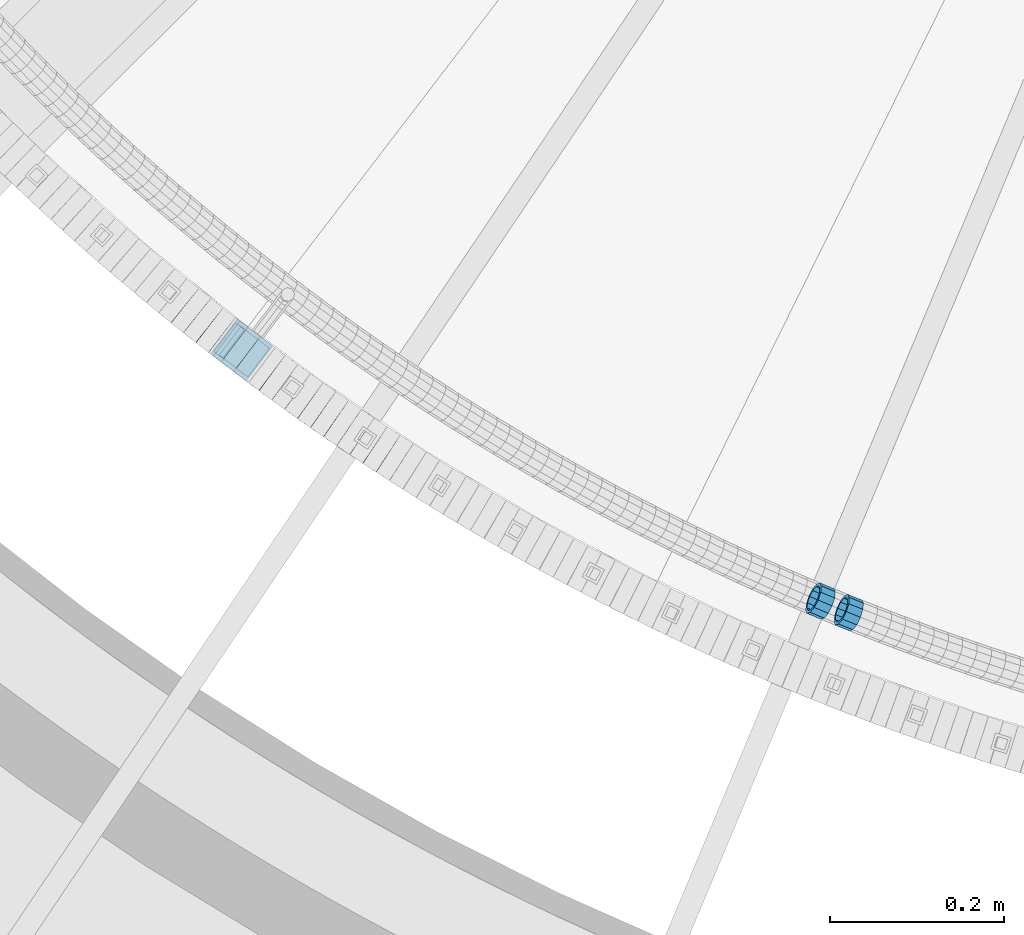
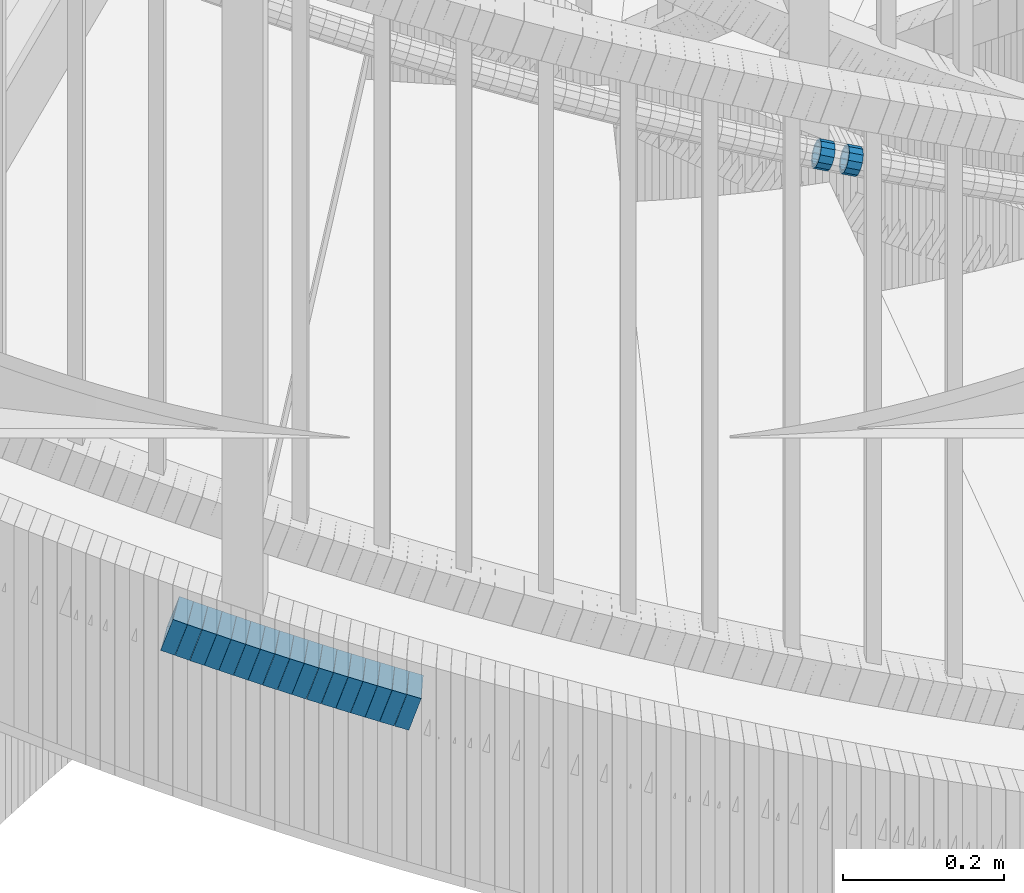
# One storey, part 649 of 975: 19 beams.
"""IFC2X3 building model written with IfcOpenShell, lengths in millimetres."""

from ifc_helpers import new_model, si_unit, frame, origin_with_axes, place, context, subcontext, project, spatial, faceted_brep, material, type_object, element, save


model = new_model("IFC2X3")

# Units and contexts
model_context = context("Model", 3, precision=1e-05, world=origin_with_axes())
body_context = subcontext(model_context, "Body", "Model", "MODEL_VIEW")
ifc_project = project(units=[si_unit("LENGTHUNIT", "METRE", prefix="MILLI"), si_unit("AREAUNIT", "SQUARE_METRE"), si_unit("VOLUMEUNIT", "CUBIC_METRE"), si_unit("MASSUNIT", "GRAM", prefix="KILO"), si_unit("TIMEUNIT", "SECOND"), si_unit("PLANEANGLEUNIT", "RADIAN"), si_unit("SOLIDANGLEUNIT", "STERADIAN"), si_unit("THERMODYNAMICTEMPERATUREUNIT", "DEGREE_CELSIUS"), si_unit("LUMINOUSINTENSITYUNIT", "LUMEN")], contexts=[model_context])

# Site, building, storey
site_placement = place(None, origin_with_axes())
site = spatial("IfcSite", under=ifc_project, at=site_placement, CompositionType="ELEMENT")
building_placement = place(site_placement, origin_with_axes())
building = spatial("IfcBuilding", under=site, at=building_placement, Name="Undefined", CompositionType="ELEMENT")
storey_placement = place(building_placement, origin_with_axes())
storey = spatial("IfcBuildingStorey", under=building, at=storey_placement, Name="Undefined", CompositionType="ELEMENT", Elevation=0.0)

# Beams
ifc_material = material()
beam_type_1 = type_object("IfcBeamType", PredefinedType="NOTDEFINED")
beam_1_placement = place(storey_placement, frame((33653.4322841467, 833.881367147236, 4572.69274639773), z_axis=(0.384208167513556, 0.92324649147228, -2.21253685595002e-10), x_axis=(0.877556871901427, -0.365194474958958, -0.31068783696507)))
element("IfcBeam", 1, at=beam_1_placement, inside=storey, type_object=beam_type_1, material=ifc_material, Name="WALL", context=body_context, shape_type="Brep", body=[
    faceted_brep([(-2.1246523829177e-07, -15.367000000002, 0.0), (-1.83998054126278e-07, -13.3082123799541, 7.68350000000009), (18.3491144200598, -13.3082123799504, 7.68349999999373), (18.3491144200925, -15.3670000000038, 7.27595761418343e-12), (-1.06232619145885e-07, -7.68349999999919, 13.3082123799559), (18.3491144200307, -7.68349999998463, 13.3082123799359), (-3.63797880709171e-12, 3.63797880709171e-12, 15.3670000000002), (18.3491144200016, 2.5465851649642e-11, 15.3669999999674), (1.06225343188271e-07, 7.68350000000646, 13.3082123799559), (18.3491144199943, 7.68350000003193, 13.3082123799177), (1.8399441614747e-07, 13.308212379965, 7.68350000000009), (18.3491144199907, 13.3082123799941, 7.68349999996281), (2.12461600312963e-07, 15.3670000000093, 0.0), (18.3491144200052, 15.3670000000347, -3.09228198602796e-11), (1.8399441614747e-07, 13.308212379965, -7.68350000000009), (18.3491144200379, 13.3082123799832, -7.68350000001556), (1.06225343188271e-07, 7.68350000000646, -13.3082123799559), (18.3491144200707, 7.68350000001374, -13.3082123799577), (-3.63797880709171e-12, 3.63797880709171e-12, -15.3670000000002), (18.3491144200962, 3.63797880709171e-12, -15.3669999999911), (-1.06232619145885e-07, -7.68349999999919, -13.3082123799559), (18.3491144201143, -7.68350000000464, -13.3082123799377), (-1.83998054126278e-07, -13.3082123799541, -7.68350000000009), (18.3491144201107, -13.3082123799632, -7.68349999998645), (-2.63386027654633e-07, -19.0500000000029, 0.0), (-2.28097633225843e-07, -16.4977839420972, -9.52499999999964), (18.349114420118, -16.4977839421044, -9.52499999997963), (18.3491144201034, -19.0500000000102, 1.09139364212751e-11), (-1.31691194837913e-07, -9.52500000000146, -16.4977839420935), (18.3491144201253, -9.52500000000873, -16.4977839420717), (-3.63797880709171e-12, 3.63797880709171e-12, -19.0500000000002), (18.3491144201071, 3.63797880709171e-12, -19.0499999999865), (1.31687556859106e-07, 9.52500000000509, -16.4977839420935), (18.3491144200743, 9.52500000001601, -16.4977839420953), (2.28097633225843e-07, 16.4977839421044, -9.52499999999964), (18.3491144200416, 16.4977839421226, -9.52500000001965), (2.63382389675826e-07, 19.0500000000138, 0.0), (18.3491144199979, 19.0500000000393, -3.63797880709171e-11), (2.28097633225843e-07, 16.4977839421044, 9.52499999999964), (18.3491144199797, 16.4977839421372, 9.52499999995598), (1.31687556859106e-07, 9.52500000000509, 16.4977839420935), (18.3491144199761, 9.52500000003783, 16.497783942048), (-3.63797880709171e-12, 3.63797880709171e-12, 19.0500000000002), (18.3491144199979, 2.72848410531878e-11, 19.0499999999647), (-1.31691194837913e-07, -9.52500000000146, 16.4977839420935), (18.349114420027, -9.52499999998327, 16.4977839420735), (-2.28097633225843e-07, -16.4977839420972, 9.52499999999964), (18.3491144200671, -16.4977839420935, 9.524999999996)], [[[0, 1, 2, 3]], [[1, 4, 5, 2]], [[4, 6, 7, 5]], [[6, 8, 9, 7]], [[8, 10, 11, 9]], [[10, 12, 13, 11]], [[12, 14, 15, 13]], [[14, 16, 17, 15]], [[16, 18, 19, 17]], [[18, 20, 21, 19]], [[20, 22, 23, 21]], [[22, 0, 3, 23]], [[24, 25, 26, 27]], [[25, 28, 29, 26]], [[28, 30, 31, 29]], [[30, 32, 33, 31]], [[32, 34, 35, 33]], [[34, 36, 37, 35]], [[36, 38, 39, 37]], [[38, 40, 41, 39]], [[40, 42, 43, 41]], [[42, 44, 45, 43]], [[44, 46, 47, 45]], [[46, 24, 27, 47]], [[29, 31, 33, 35, 37, 39, 41, 43, 45, 47, 27, 26], [5, 7, 9, 11, 13, 15, 17, 19, 21, 23, 3, 2]], [[46, 44, 42, 40, 38, 36, 34, 32, 30, 28, 25, 24], [22, 20, 18, 16, 14, 12, 10, 8, 6, 4, 1, 0]]]),
])
beam_2_placement = place(storey_placement, frame((33685.730099739, 820.487289697012, 4561.18183881547), z_axis=(0.370407953664464, 0.928869176936184, 9.3559719971381e-11), x_axis=(0.883433150707989, -0.352289292883568, -0.308930610897902)))
element("IfcBeam", 2, at=beam_2_placement, inside=storey, type_object=beam_type_1, material=ifc_material, Name="WALL", context=body_context, shape_type="Brep", body=[
    faceted_brep([(-2.1246523829177e-07, -15.367000000002, 0.0), (-1.83998054126278e-07, -13.3082123799541, 7.68350000000009), (18.4537259110693, -13.3082123799595, 7.68349999998827), (18.453725911073, -15.3670000000038, 0.0), (-1.06232619145885e-07, -7.68349999999919, 13.3082123799559), (18.4537259110621, -7.683500000001, 13.3082123799431), (-3.63797880709171e-12, 3.63797880709171e-12, 15.3670000000002), (18.453725911073, -1.81898940354586e-12, 15.3669999999911), (1.06225343188271e-07, 7.68350000000646, 13.3082123799559), (18.4537259110839, 7.68349999999737, 13.3082123799504), (1.8399441614747e-07, 13.308212379965, 7.68350000000009), (18.4537259110948, 13.3082123799522, 7.68350000000646), (2.12461600312963e-07, 15.3670000000093, 0.0), (18.4537259111057, 15.3669999999947, 1.09139364212751e-11), (1.8399441614747e-07, 13.308212379965, -7.68350000000009), (18.4537259111203, 13.3082123799486, -7.68349999997372), (1.06225343188271e-07, 7.68350000000646, -13.3082123799559), (18.4537259111166, 7.68349999999373, -13.3082123799322), (-3.63797880709171e-12, 3.63797880709171e-12, -15.3670000000002), (18.4537259111094, -5.45696821063757e-12, -15.3669999999765), (-1.06232619145885e-07, -7.68349999999919, -13.3082123799559), (18.4537259111057, -7.68350000000646, -13.3082123799395), (-1.83998054126278e-07, -13.3082123799541, -7.68350000000009), (18.4537259110912, -13.3082123799595, -7.68349999999555), (-2.63386027654633e-07, -19.0500000000029, 0.0), (-2.28097633225843e-07, -16.4977839420972, -9.52499999999964), (18.4537259110839, -16.497783942099, -9.52499999999418), (18.453725911073, -19.0500000000029, -7.27595761418343e-12), (-1.31691194837913e-07, -9.52500000000146, -16.4977839420935), (18.4537259111057, -9.52500000000509, -16.497783942079), (-3.63797880709171e-12, 3.63797880709171e-12, -19.0500000000002), (18.4537259111166, -7.27595761418343e-12, -19.0499999999702), (1.31687556859106e-07, 9.52500000000509, -16.4977839420935), (18.4537259111275, 9.52499999999236, -16.4977839420608), (2.28097633225843e-07, 16.4977839421044, -9.52499999999964), (18.4537259111239, 16.4977839420881, -9.52499999997235), (2.63382389675826e-07, 19.0500000000138, 0.0), (18.4537259111057, 19.0499999999938, 1.81898940354586e-11), (2.28097633225843e-07, 16.4977839421044, 9.52499999999964), (18.4537259110948, 16.4977839420917, 9.52500000000509), (1.31687556859106e-07, 9.52500000000509, 16.4977839420935), (18.4537259110803, 9.52499999999782, 16.4977839420862), (-3.63797880709171e-12, 3.63797880709171e-12, 19.0500000000002), (18.4537259110621, -1.81898940354586e-12, 19.0499999999811), (-1.31691194837913e-07, -9.52500000000146, 16.4977839420935), (18.4537259110584, -9.52500000000146, 16.4977839420753), (-2.28097633225843e-07, -16.4977839420972, 9.52499999999964), (18.4537259110621, -16.4977839420953, 9.52499999998327)], [[[0, 1, 2, 3]], [[1, 4, 5, 2]], [[4, 6, 7, 5]], [[6, 8, 9, 7]], [[8, 10, 11, 9]], [[10, 12, 13, 11]], [[12, 14, 15, 13]], [[14, 16, 17, 15]], [[16, 18, 19, 17]], [[18, 20, 21, 19]], [[20, 22, 23, 21]], [[22, 0, 3, 23]], [[24, 25, 26, 27]], [[25, 28, 29, 26]], [[28, 30, 31, 29]], [[30, 32, 33, 31]], [[32, 34, 35, 33]], [[34, 36, 37, 35]], [[36, 38, 39, 37]], [[38, 40, 41, 39]], [[40, 42, 43, 41]], [[42, 44, 45, 43]], [[44, 46, 47, 45]], [[46, 24, 27, 47]], [[29, 31, 33, 35, 37, 39, 41, 43, 45, 47, 27, 26], [5, 7, 9, 11, 13, 15, 17, 19, 21, 23, 3, 2]], [[46, 44, 42, 40, 38, 36, 34, 32, 30, 28, 25, 24], [22, 20, 18, 16, 14, 12, 10, 8, 6, 4, 1, 0]]]),
])
beam_type_2 = type_object("IfcBeamType", Name="HSS2X2X.188_TUBES", PredefinedType="NOTDEFINED")
beam_3_placement = place(storey_placement, frame((32925.6931023525, 1174.52376086977, 3910.43312083573), z_axis=(0.624695047600639, 0.780868809406059, 1.82944404514274e-10), x_axis=(0.742959140417753, -0.594367312334205, -0.307797358173079)))
element("IfcBeam", 3, at=beam_3_placement, inside=storey, type_object=beam_type_2, material=ifc_material, Name="WALL", ObjectType="HSS2X2X.188_TUBES", context=body_context, shape_type="Brep", body=[
    faceted_brep([(0.0, 20.6374999999753, -20.6375000000298), (0.0, -20.6375000000153, -20.6375000000153), (18.8433011969464, -20.6374999999898, -20.6375000000226), (18.8433011969719, 20.6375000000007, -20.6374999999862), (0.0, -20.6374999999825, 20.6375000000335), (18.8433011969828, -20.6375000000044, 20.6375000000189), (0.0, 20.6375000000116, 20.6375000000189), (18.8433011970155, 20.6374999999862, 20.6375000000517), (0.0, 25.3999999999724, -25.4000000000342), (0.0, 25.400000000016, 25.4000000000196), (18.8433011970228, 25.3999999999833, 25.4000000000597), (18.8433011969719, 25.4000000000015, -25.3999999999869), (0.0, -25.399999999976, 25.4000000000378), (18.8433011969864, -25.4000000000051, 25.4000000000196), (0.0, -25.400000000016, -25.4000000000196), (18.8433011969391, -25.3999999999869, -25.4000000000269)], [[[0, 1, 2, 3]], [[1, 4, 5, 2]], [[4, 6, 7, 5]], [[6, 0, 3, 7]], [[8, 9, 10, 11]], [[9, 12, 13, 10]], [[12, 14, 15, 13]], [[14, 8, 11, 15]], [[13, 15, 11, 10], [5, 7, 3, 2]], [[14, 12, 9, 8], [6, 4, 1, 0]]]),
])
beam_4_placement = place(storey_placement, frame((32939.8354157942, 1163.16701080434, 3904.60164874972), z_axis=(0.621276225268862, 0.78359163594035, -7.90359990787692e-11), x_axis=(0.746520694737996, -0.591884264792277, -0.303940568893337)))
element("IfcBeam", 4, at=beam_4_placement, inside=storey, type_object=beam_type_2, material=ifc_material, Name="WALL", ObjectType="HSS2X2X.188_TUBES", context=body_context, shape_type="Brep", body=[
    faceted_brep([(0.0, 20.6374999999753, -20.6375000000298), (0.0, -20.6375000000153, -20.6375000000153), (18.7547327359644, -20.6374999999844, -20.6375000000553), (18.7547327359898, 20.6375000000171, -20.6375000000335), (0.0, -20.6374999999825, 20.6375000000335), (18.7547327360044, -20.6374999999953, 20.6374999999898), (0.0, 20.6375000000116, 20.6375000000189), (18.7547327360262, 20.6375000000062, 20.6375000000116), (0.0, 25.3999999999724, -25.4000000000342), (0.0, 25.400000000016, 25.4000000000196), (18.7547327360371, 25.4000000000033, 25.4000000000124), (18.7547327359898, 25.4000000000178, -25.4000000000342), (0.0, -25.399999999976, 25.4000000000378), (18.7547327360044, -25.399999999996, 25.3999999999869), (0.0, -25.400000000016, -25.4000000000196), (18.7547327359498, -25.3999999999814, -25.4000000000597)], [[[0, 1, 2, 3]], [[1, 4, 5, 2]], [[4, 6, 7, 5]], [[6, 0, 3, 7]], [[8, 9, 10, 11]], [[9, 12, 13, 10]], [[12, 14, 15, 13]], [[14, 8, 11, 15]], [[13, 15, 11, 10], [5, 7, 3, 2]], [[14, 12, 9, 8], [6, 4, 1, 0]]]),
])
beam_5_placement = place(storey_placement, frame((32954.0367563121, 1151.79884361767, 3898.88975745706), z_axis=(0.612397742431603, 0.790549811880742, -1.31450178741943e-10), x_axis=(0.75351979107376, -0.583712515057146, -0.302469212029619)))
element("IfcBeam", 5, at=beam_5_placement, inside=storey, type_object=beam_type_2, material=ifc_material, Name="WALL", ObjectType="HSS2X2X.188_TUBES", context=body_context, shape_type="Brep", body=[
    faceted_brep([(0.0, 20.6374999999753, -20.6375000000298), (0.0, -20.6375000000153, -20.6375000000153), (18.8433011969464, -20.6374999999898, -20.6375000000226), (18.8433011969719, 20.6375000000007, -20.6374999999862), (0.0, -20.6374999999825, 20.6375000000335), (18.8433011969828, -20.6375000000044, 20.6375000000189), (0.0, 20.6375000000116, 20.6375000000189), (18.8433011970155, 20.6374999999862, 20.6375000000517), (0.0, 25.3999999999724, -25.4000000000342), (0.0, 25.400000000016, 25.4000000000196), (18.8433011970228, 25.3999999999833, 25.4000000000597), (18.8433011969719, 25.4000000000015, -25.3999999999869), (0.0, -25.399999999976, 25.4000000000378), (18.8433011969864, -25.4000000000051, 25.4000000000196), (0.0, -25.400000000016, -25.4000000000196), (18.8433011969391, -25.3999999999869, -25.4000000000269)], [[[0, 1, 2, 3]], [[1, 4, 5, 2]], [[4, 6, 7, 5]], [[6, 0, 3, 7]], [[8, 9, 10, 11]], [[9, 12, 13, 10]], [[12, 14, 15, 13]], [[14, 8, 11, 15]], [[13, 15, 11, 10], [5, 7, 3, 2]], [[14, 12, 9, 8], [6, 4, 1, 0]]]),
])
beam_6_placement = place(storey_placement, frame((32968.1888492451, 1140.7925334783, 3893.23665673552), z_axis=(0.608900540899225, 0.793246576603159, 1.44894784170902e-10), x_axis=(0.754625564178274, -0.579254834136836, -0.308227343072818)))
element("IfcBeam", 6, at=beam_6_placement, inside=storey, type_object=beam_type_2, material=ifc_material, Name="WALL", ObjectType="HSS2X2X.188_TUBES", context=body_context, shape_type="Brep", body=[
    faceted_brep([(0.0, 20.6374999999753, -20.6375000000298), (0.0, -20.6375000000153, -20.6375000000153), (18.8225928075335, -20.6374999999935, -20.6375000000298), (18.8225928075699, 20.6374999999898, -20.6374999999825), (0.0, -20.6374999999825, 20.6375000000335), (18.8225928075772, -20.637500000008, 20.6375000000226), (0.0, 20.6375000000116, 20.6375000000189), (18.8225928076135, 20.6374999999753, 20.6375000000698), (0.0, 25.3999999999724, -25.4000000000342), (0.0, 25.400000000016, 25.4000000000196), (18.8225928076281, 25.3999999999705, 25.4000000000815), (18.8225928075663, 25.3999999999905, -25.3999999999796), (0.0, -25.399999999976, 25.4000000000378), (18.8225928075808, -25.4000000000087, 25.4000000000233), (0.0, -25.400000000016, -25.4000000000196), (18.8225928075226, -25.3999999999905, -25.4000000000378)], [[[0, 1, 2, 3]], [[1, 4, 5, 2]], [[4, 6, 7, 5]], [[6, 0, 3, 7]], [[8, 9, 10, 11]], [[9, 12, 13, 10]], [[12, 14, 15, 13]], [[14, 8, 11, 15]], [[13, 15, 11, 10], [5, 7, 3, 2]], [[14, 12, 9, 8], [6, 4, 1, 0]]]),
])
beam_7_placement = place(storey_placement, frame((32982.4659690608, 1129.80023058132, 3887.42653205326), z_axis=(0.606210766739459, 0.795304033869537, 4.13278939959127e-11), x_axis=(0.756899865168281, -0.576937659128279, -0.306994351068256)))
element("IfcBeam", 7, at=beam_7_placement, inside=storey, type_object=beam_type_2, material=ifc_material, Name="WALL", ObjectType="HSS2X2X.188_TUBES", context=body_context, shape_type="Brep", body=[
    faceted_brep([(0.0, 20.6374999999753, -20.6375000000298), (0.0, -20.6375000000153, -20.6375000000153), (18.891267824034, -20.6375000000153, -20.6374999999971), (18.891267824034, 20.6375000000025, -20.637500000008), (0.0, -20.6374999999825, 20.6375000000335), (18.8912678240486, -20.6374999999989, 20.6375000000153), (0.0, 20.6375000000116, 20.6375000000189), (18.8912678240449, 20.6375000000189, 20.6375000000007), (0.0, 25.3999999999724, -25.4000000000342), (0.0, 25.400000000016, 25.4000000000196), (18.8912678240467, 25.4000000000215, 25.4000000000051), (18.8912678240304, 25.4000000000033, -25.4000000000124), (0.0, -25.399999999976, 25.4000000000378), (18.8912678240504, -25.3999999999996, 25.400000000016), (0.0, -25.400000000016, -25.4000000000196), (18.891267824034, -25.4000000000178, -25.3999999999978)], [[[0, 1, 2, 3]], [[1, 4, 5, 2]], [[4, 6, 7, 5]], [[6, 0, 3, 7]], [[8, 9, 10, 11]], [[9, 12, 13, 10]], [[12, 14, 15, 13]], [[14, 8, 11, 15]], [[13, 15, 11, 10], [5, 7, 3, 2]], [[14, 12, 9, 8], [6, 4, 1, 0]]]),
])
beam_8_placement = place(storey_placement, frame((32996.913498833, 1118.74512883822, 3881.59496325694), z_axis=(0.602675192946082, 0.797986598764292, -3.14994395012037e-11), x_axis=(0.760444683064175, -0.574321858048454, -0.303114314025581)))
element("IfcBeam", 8, at=beam_8_placement, inside=storey, type_object=beam_type_2, material=ifc_material, Name="WALL", ObjectType="HSS2X2X.188_TUBES", context=body_context, shape_type="Brep", body=[
    faceted_brep([(0.0, 20.6374999999753, -20.6375000000298), (0.0, -20.6375000000153, -20.6375000000153), (18.8047866246379, -20.6374999999916, -20.6375000000298), (18.8047866247143, 20.6374999999844, -20.6374999999643), (0.0, -20.6374999999825, 20.6375000000335), (18.8047866247107, -20.6375000000189, 20.6375000000407), (0.0, 20.6375000000116, 20.6375000000189), (18.8047866247907, 20.6374999999589, 20.6375000001026), (0.0, 25.3999999999724, -25.4000000000342), (0.0, 25.400000000016, 25.4000000000196), (18.8047866248016, 25.3999999999542, 25.4000000001142), (18.8047866247143, 25.3999999999851, -25.3999999999651), (0.0, -25.399999999976, 25.4000000000378), (18.8047866247107, -25.4000000000196, 25.4000000000415), (0.0, -25.400000000016, -25.4000000000196), (18.8047866246197, -25.3999999999887, -25.4000000000378)], [[[0, 1, 2, 3]], [[1, 4, 5, 2]], [[4, 6, 7, 5]], [[6, 0, 3, 7]], [[8, 9, 10, 11]], [[9, 12, 13, 10]], [[12, 14, 15, 13]], [[14, 8, 11, 15]], [[13, 15, 11, 10], [5, 7, 3, 2]], [[14, 12, 9, 8], [6, 4, 1, 0]]]),
])
beam_9_placement = place(storey_placement, frame((33011.2647168124, 1107.86352473887, 3875.9024546398), z_axis=(0.59910376760181, 0.800671390550029, 2.06918230105657e-10), x_axis=(0.762767019599647, -0.570741755700445, -0.304040000840426)))
element("IfcBeam", 9, at=beam_9_placement, inside=storey, type_object=beam_type_2, material=ifc_material, Name="WALL", ObjectType="HSS2X2X.188_TUBES", context=body_context, shape_type="Brep", body=[
    faceted_brep([(0.0, 20.6374999999753, -20.6375000000298), (0.0, -20.6375000000153, -20.6375000000153), (18.7547327359644, -20.6374999999844, -20.6375000000553), (18.7547327359898, 20.6375000000171, -20.6375000000335), (0.0, -20.6374999999825, 20.6375000000335), (18.7547327360044, -20.6374999999953, 20.6374999999898), (0.0, 20.6375000000116, 20.6375000000189), (18.7547327360262, 20.6375000000062, 20.6375000000116), (0.0, 25.3999999999724, -25.4000000000342), (0.0, 25.400000000016, 25.4000000000196), (18.7547327360371, 25.4000000000033, 25.4000000000124), (18.7547327359898, 25.4000000000178, -25.4000000000342), (0.0, -25.399999999976, 25.4000000000378), (18.7547327360044, -25.399999999996, 25.3999999999869), (0.0, -25.400000000016, -25.4000000000196), (18.7547327359498, -25.3999999999814, -25.4000000000597)], [[[0, 1, 2, 3]], [[1, 4, 5, 2]], [[4, 6, 7, 5]], [[6, 0, 3, 7]], [[8, 9, 10, 11]], [[9, 12, 13, 10]], [[12, 14, 15, 13]], [[14, 8, 11, 15]], [[13, 15, 11, 10], [5, 7, 3, 2]], [[14, 12, 9, 8], [6, 4, 1, 0]]]),
])
beam_10_placement = place(storey_placement, frame((33025.6742071288, 1096.97507598524, 3870.2289680424), z_axis=(0.590156170756825, 0.807289101944057, 5.27320480614435e-11), x_axis=(0.768228767190354, -0.561601719139159, -0.307291507076148)))
element("IfcBeam", 10, at=beam_10_placement, inside=storey, type_object=beam_type_2, material=ifc_material, Name="WALL", ObjectType="HSS2X2X.188_TUBES", context=body_context, shape_type="Brep", body=[
    faceted_brep([(0.0, 20.6374999999753, -20.6375000000298), (0.0, -20.6375000000153, -20.6375000000153), (18.8653120832787, -20.6374999999989, -20.6374999999935), (18.8653120832823, 20.6374999999971, -20.6374999999935), (0.0, -20.6374999999825, 20.6375000000335), (18.8653120833151, -20.6375000000116, 20.6375000000298), (0.0, 20.6375000000116, 20.6375000000189), (18.8653120833151, 20.6374999999844, 20.6375000000298), (0.0, 25.3999999999724, -25.4000000000342), (0.0, 25.400000000016, 25.4000000000196), (18.8653120833187, 25.3999999999814, 25.4000000000378), (18.8653120832823, 25.3999999999942, -25.3999999999905), (0.0, -25.399999999976, 25.4000000000378), (18.8653120833187, -25.4000000000124, 25.4000000000342), (0.0, -25.400000000016, -25.4000000000196), (18.8653120832787, -25.3999999999978, -25.3999999999942)], [[[0, 1, 2, 3]], [[1, 4, 5, 2]], [[4, 6, 7, 5]], [[6, 0, 3, 7]], [[8, 9, 10, 11]], [[9, 12, 13, 10]], [[12, 14, 15, 13]], [[14, 8, 11, 15]], [[13, 15, 11, 10], [5, 7, 3, 2]], [[14, 12, 9, 8], [6, 4, 1, 0]]]),
])
beam_11_placement = place(storey_placement, frame((33040.3264904772, 1086.22102742852, 3864.3971487143), z_axis=(0.58650981199336, 0.809942121657784, -6.21935214439872e-11), x_axis=(0.771768059992756, -0.558866525994744, -0.303384685997142)))
element("IfcBeam", 11, at=beam_11_placement, inside=storey, type_object=beam_type_2, material=ifc_material, Name="WALL", ObjectType="HSS2X2X.188_TUBES", context=body_context, shape_type="Brep", body=[
    faceted_brep([(0.0, 20.6374999999753, -20.6375000000298), (0.0, -20.6375000000153, -20.6375000000153), (18.7853666454903, -20.6375000000535, -20.6375000000326), (18.785366645363, 20.6374999999862, -20.6375000000044), (0.0, -20.6374999999825, 20.6375000000335), (18.785366645352, -20.6375000000007, 20.6374999999989), (0.0, 20.6375000000116, 20.6375000000189), (18.7853666453102, 20.6375000000025, 20.6374999999753), (0.0, 25.3999999999724, -25.4000000000342), (0.0, 25.400000000016, 25.4000000000196), (18.7853666452065, 25.4000000000451, 25.4000000000351), (18.7853666453739, 25.3999999999833, -25.400000000006), (0.0, -25.399999999976, 25.4000000000378), (18.7853666497213, -25.399999993424, 25.3999999995158), (0.0, -25.400000000016, -25.4000000000196), (18.7853666455194, -25.4000000000633, -25.4000000000406)], [[[0, 1, 2, 3]], [[1, 4, 5, 2]], [[4, 6, 7, 5]], [[6, 0, 3, 7]], [[8, 9, 10, 11]], [[9, 12, 13, 10]], [[12, 14, 15, 13]], [[14, 8, 11, 15]], [[13, 15, 11, 10], [5, 7, 3, 2]], [[14, 12, 9, 8], [6, 4, 1, 0]]]),
])
beam_12_placement = place(storey_placement, frame((33054.7812147917, 1075.7101349536, 3858.74400719722), z_axis=(0.582827438797177, 0.812595949156235, 8.31673787615729e-11), x_axis=(0.772797712841647, -0.554282496886418, -0.30911908493666)))
element("IfcBeam", 12, at=beam_12_placement, inside=storey, type_object=beam_type_2, material=ifc_material, Name="WALL", ObjectType="HSS2X2X.188_TUBES", context=body_context, shape_type="Brep", body=[
    faceted_brep([(0.0, 20.6374999999753, -20.6375000000298), (0.0, -20.6375000000153, -20.6375000000153), (18.7555325170906, -20.6374999999916, -20.6374999999971), (18.7555325171452, 20.637499999988, -20.6374999999571), (0.0, -20.6374999999825, 20.6375000000335), (18.7555325170615, -20.6374999999844, 20.6374999999716), (0.0, 20.6375000000116, 20.6375000000189), (18.7555325171015, 20.6374999999953, 20.637500000008), (0.0, 25.3999999999724, -25.4000000000342), (0.0, 25.400000000016, 25.4000000000196), (18.7555325171015, 25.399999999996, 25.4000000000051), (18.7555325171488, 25.3999999999851, -25.3999999999505), (0.0, -25.399999999976, 25.4000000000378), (18.755532517047, -25.3999999999814, 25.3999999999578), (0.0, -25.400000000016, -25.4000000000196), (18.7555325170979, -25.3999999999924, -25.3999999999978)], [[[0, 1, 2, 3]], [[1, 4, 5, 2]], [[4, 6, 7, 5]], [[6, 0, 3, 7]], [[8, 9, 10, 11]], [[9, 12, 13, 10]], [[12, 14, 15, 13]], [[14, 8, 11, 15]], [[13, 15, 11, 10], [5, 7, 3, 2]], [[14, 12, 9, 8], [6, 4, 1, 0]]]),
])
beam_13_placement = place(storey_placement, frame((33069.5151544565, 1065.06910390618, 3852.90150870524), z_axis=(0.576463443844703, 0.817122939288027, 9.34501258598175e-11), x_axis=(0.778470170843609, -0.549194709889666, -0.303923285938948)))
element("IfcBeam", 13, at=beam_13_placement, inside=storey, type_object=beam_type_2, material=ifc_material, Name="WALL", ObjectType="HSS2X2X.188_TUBES", context=body_context, shape_type="Brep", body=[
    faceted_brep([(0.0, 20.6374999999753, -20.6375000000298), (0.0, -20.6375000000153, -20.6375000000153), (18.7547327359644, -20.6374999999844, -20.6375000000553), (18.7547327359898, 20.6375000000171, -20.6375000000335), (0.0, -20.6374999999825, 20.6375000000335), (18.7547327360044, -20.6374999999953, 20.6374999999898), (0.0, 20.6375000000116, 20.6375000000189), (18.7547327360262, 20.6375000000062, 20.6375000000116), (0.0, 25.3999999999724, -25.4000000000342), (0.0, 25.400000000016, 25.4000000000196), (18.7547327360371, 25.4000000000033, 25.4000000000124), (18.7547327359898, 25.4000000000178, -25.4000000000342), (0.0, -25.399999999976, 25.4000000000378), (18.7547327360044, -25.399999999996, 25.3999999999869), (0.0, -25.400000000016, -25.4000000000196), (18.7547327359498, -25.3999999999814, -25.4000000000597)], [[[0, 1, 2, 3]], [[1, 4, 5, 2]], [[4, 6, 7, 5]], [[6, 0, 3, 7]], [[8, 9, 10, 11]], [[9, 12, 13, 10]], [[12, 14, 15, 13]], [[14, 8, 11, 15]], [[13, 15, 11, 10], [5, 7, 3, 2]], [[14, 12, 9, 8], [6, 4, 1, 0]]]),
])
beam_14_placement = place(storey_placement, frame((33084.250703983, 1054.60092767865, 3847.19843596918), z_axis=(0.570081548267715, 0.821588113548806, -1.5201430869638e-10), x_axis=(0.782823517351619, -0.543183665243989, -0.303543813136334)))
element("IfcBeam", 14, at=beam_14_placement, inside=storey, type_object=beam_type_2, material=ifc_material, Name="WALL", ObjectType="HSS2X2X.188_TUBES", context=body_context, shape_type="Brep", body=[
    faceted_brep([(0.0, 20.6374999999753, -20.6375000000298), (0.0, -20.6375000000153, -20.6375000000153), (18.7771137292038, -20.637500000008, -20.6374999999862), (18.777113729182, 20.6375000000062, -20.6375000000189), (0.0, -20.6374999999825, 20.6375000000335), (18.7771137291729, -20.6374999999916, 20.6374999999753), (0.0, 20.6375000000116, 20.6375000000189), (18.7771137291529, 20.6375000000207, 20.6374999999389), (0.0, 25.3999999999724, -25.4000000000342), (0.0, 25.400000000016, 25.4000000000196), (18.7771137291475, 25.4000000000251, 25.3999999999287), (18.7771137291857, 25.4000000000051, -25.4000000000196), (0.0, -25.399999999976, 25.4000000000378), (18.7771137291711, -25.3999999999905, 25.3999999999724), (0.0, -25.400000000016, -25.4000000000196), (18.7771137292129, -25.4000000000124, -25.3999999999724)], [[[0, 1, 2, 3]], [[1, 4, 5, 2]], [[4, 6, 7, 5]], [[6, 0, 3, 7]], [[8, 9, 10, 11]], [[9, 12, 13, 10]], [[12, 14, 15, 13]], [[14, 8, 11, 15]], [[13, 15, 11, 10], [5, 7, 3, 2]], [[14, 12, 9, 8], [6, 4, 1, 0]]]),
])
beam_15_placement = place(storey_placement, frame((33098.9864871925, 1044.30308192429, 3841.53451134792), z_axis=(0.563683129387442, 0.825991119591477, -1.78132268047193e-10), x_axis=(0.785845631236314, -0.536286546161269, -0.307966531092611)))
element("IfcBeam", 15, at=beam_15_placement, inside=storey, type_object=beam_type_2, material=ifc_material, Name="WALL", ObjectType="HSS2X2X.188_TUBES", context=body_context, shape_type="Brep", body=[
    faceted_brep([(0.0, 20.6374999999753, -20.6375000000298), (0.0, -20.6375000000153, -20.6375000000153), (18.8332159191086, -20.6374999999916, -20.6375000000153), (18.8332159190923, 20.6375000000062, -20.6375000000335), (0.0, -20.6374999999825, 20.6375000000335), (18.8332159191377, -20.6375000000062, 20.6375000000335), (0.0, 20.6375000000116, 20.6375000000189), (18.8332159191141, 20.6374999999916, 20.6375000000116), (0.0, 25.3999999999724, -25.4000000000342), (0.0, 25.400000000016, 25.4000000000196), (18.8332159191159, 25.3999999999905, 25.4000000000124), (18.8332159190886, 25.4000000000069, -25.4000000000415), (0.0, -25.399999999976, 25.4000000000378), (18.8332159191395, -25.4000000000069, 25.4000000000378), (0.0, -25.400000000016, -25.4000000000196), (18.8332159191104, -25.3999999999905, -25.400000000016)], [[[0, 1, 2, 3]], [[1, 4, 5, 2]], [[4, 6, 7, 5]], [[6, 0, 3, 7]], [[8, 9, 10, 11]], [[9, 12, 13, 10]], [[12, 14, 15, 13]], [[14, 8, 11, 15]], [[13, 15, 11, 10], [5, 7, 3, 2]], [[14, 12, 9, 8], [6, 4, 1, 0]]]),
])
beam_16_placement = place(storey_placement, frame((33113.9465236398, 1034.05096471743, 3835.70224430335), z_axis=(0.559857411141056, 0.828588968783941, -7.58991518523543e-11), x_axis=(0.789369820595938, -0.533357986726988, -0.304014052844389)))
element("IfcBeam", 16, at=beam_16_placement, inside=storey, type_object=beam_type_2, material=ifc_material, Name="WALL", ObjectType="HSS2X2X.188_TUBES", context=body_context, shape_type="Brep", body=[
    faceted_brep([(0.0, 20.6374999999753, -20.6375000000298), (0.0, -20.6375000000153, -20.6375000000153), (18.7547327359644, -20.6374999999844, -20.6375000000553), (18.7547327359898, 20.6375000000171, -20.6375000000335), (0.0, -20.6374999999825, 20.6375000000335), (18.7547327360044, -20.6374999999953, 20.6374999999898), (0.0, 20.6375000000116, 20.6375000000189), (18.7547327360262, 20.6375000000062, 20.6375000000116), (0.0, 25.3999999999724, -25.4000000000342), (0.0, 25.400000000016, 25.4000000000196), (18.7547327360371, 25.4000000000033, 25.4000000000124), (18.7547327359898, 25.4000000000178, -25.4000000000342), (0.0, -25.399999999976, 25.4000000000378), (18.7547327360044, -25.399999999996, 25.3999999999869), (0.0, -25.400000000016, -25.4000000000196), (18.7547327359498, -25.3999999999814, -25.4000000000597)], [[[0, 1, 2, 3]], [[1, 4, 5, 2]], [[4, 6, 7, 5]], [[6, 0, 3, 7]], [[8, 9, 10, 11]], [[9, 12, 13, 10]], [[12, 14, 15, 13]], [[14, 8, 11, 15]], [[13, 15, 11, 10], [5, 7, 3, 2]], [[14, 12, 9, 8], [6, 4, 1, 0]]]),
])
beam_17_placement = place(storey_placement, frame((33128.8063217959, 1023.96740178029, 3830.00925996803), z_axis=(0.555995550250453, 0.831185267014338, -6.40889084024821e-11), x_axis=(0.791613650352371, -0.529525347235714, -0.304878230135723)))
element("IfcBeam", 17, at=beam_17_placement, inside=storey, type_object=beam_type_2, material=ifc_material, Name="WALL", ObjectType="HSS2X2X.188_TUBES", context=body_context, shape_type="Brep", body=[
    faceted_brep([(0.0, 20.6374999999753, -20.6375000000298), (0.0, -20.6375000000153, -20.6375000000153), (18.6959888745805, -20.6374999999771, -20.6375000000407), (18.6959888746751, 20.637499999988, -20.6374999999716), (0.0, -20.6374999999825, 20.6375000000335), (18.6959888746969, -20.6375000000135, 20.6375000000371), (0.0, 20.6375000000116, 20.6375000000189), (18.6959888747988, 20.6374999999498, 20.6375000001062), (0.0, 25.3999999999724, -25.4000000000342), (0.0, 25.400000000016, 25.4000000000196), (18.695988874817, 25.3999999999414, 25.4000000001215), (18.6959888746678, 25.3999999999887, -25.399999999976), (0.0, -25.399999999976, 25.4000000000378), (18.6959888747042, -25.4000000000124, 25.4000000000378), (0.0, -25.400000000016, -25.4000000000196), (18.695988874555, -25.3999999999687, -25.4000000000597)], [[[0, 1, 2, 3]], [[1, 4, 5, 2]], [[4, 6, 7, 5]], [[6, 0, 3, 7]], [[8, 9, 10, 11]], [[9, 12, 13, 10]], [[12, 14, 15, 13]], [[14, 8, 11, 15]], [[13, 15, 11, 10], [5, 7, 3, 2]], [[14, 12, 9, 8], [6, 4, 1, 0]]]),
])
for number, where, z_axis, x_axis, name in (
    (18, (33143.644317043, 1013.96939662825, 3824.34531342347), (0.549513512408725, 0.835484829114345, -9.06243258214091e-11), (0.794522606033434, -0.522571916022, -0.30927725601301), "WALL"),
    (19, (33158.7887210317, 1003.93790583539, 3818.50206907921), (0.543019139473726, 0.839720319014143, 1.43465058499714e-10), (0.799980089763614, -0.517320457847134, -0.303992433910174), "WALL"),
):
    element("IfcBeam", number, at=place(storey_placement, frame(where, z_axis=z_axis, x_axis=x_axis)), inside=storey, type_object=beam_type_2, material=ifc_material, Name=name, ObjectType="HSS2X2X.188_TUBES", context=body_context, shape_type="Brep", body=[
        faceted_brep([(0.0, 20.6374999999753, -20.6375000000298), (0.0, -20.6375000000153, -20.6375000000153), (18.7547327359644, -20.6374999999844, -20.6375000000553), (18.7547327359898, 20.6375000000171, -20.6375000000335), (0.0, -20.6374999999825, 20.6375000000335), (18.7547327360044, -20.6374999999953, 20.6374999999898), (0.0, 20.6375000000116, 20.6375000000189), (18.7547327360262, 20.6375000000062, 20.6375000000116), (0.0, 25.3999999999724, -25.4000000000342), (0.0, 25.400000000016, 25.4000000000196), (18.7547327360371, 25.4000000000033, 25.4000000000124), (18.7547327359898, 25.4000000000178, -25.4000000000342), (0.0, -25.399999999976, 25.4000000000378), (18.7547327360044, -25.399999999996, 25.3999999999869), (0.0, -25.400000000016, -25.4000000000196), (18.7547327359498, -25.3999999999814, -25.4000000000597)], [[[0, 1, 2, 3]], [[1, 4, 5, 2]], [[4, 6, 7, 5]], [[6, 0, 3, 7]], [[8, 9, 10, 11]], [[9, 12, 13, 10]], [[12, 14, 15, 13]], [[14, 8, 11, 15]], [[13, 15, 11, 10], [5, 7, 3, 2]], [[14, 12, 9, 8], [6, 4, 1, 0]]]),
    ])

save(model, "model.ifc")
